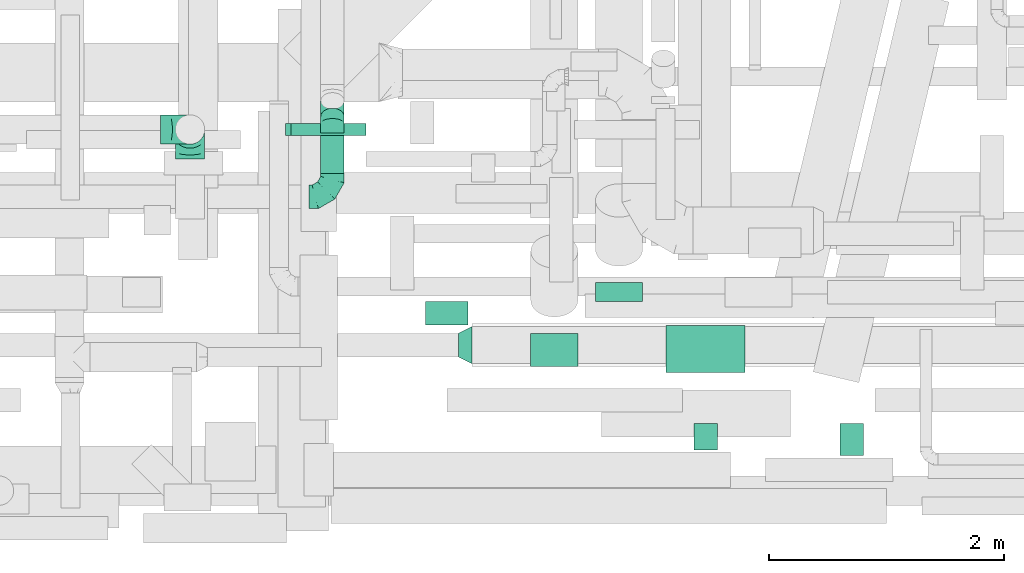
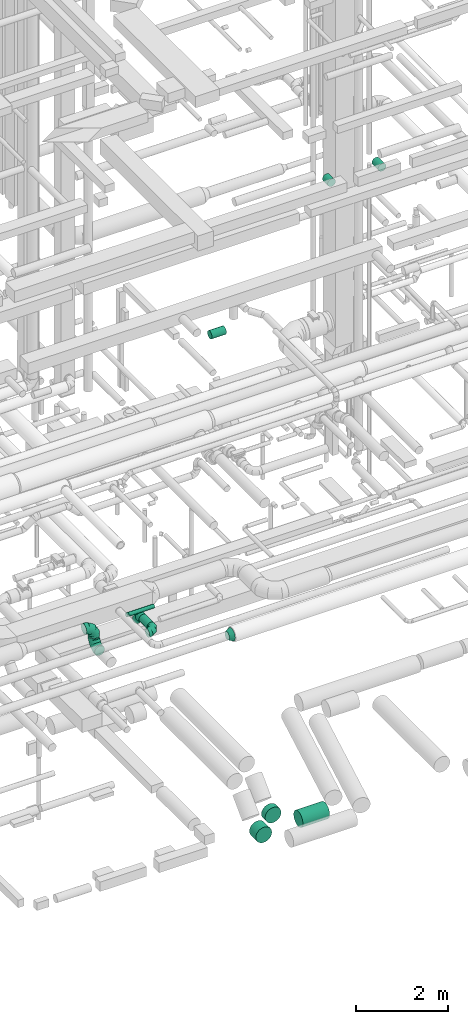
# One storey, part 163 of 337: 9 flow segments, 6 flow fittings.
"""IFC2X3 building model written with IfcOpenShell, lengths in millimetres."""

from ifc_helpers import new_model, entity, si_unit, converted_unit, derived_unit, direction, frame, origin, origin_2d_with_axis, place, context, subcontext, project, spatial, circle, extrude, faceted_brep, source, transform, mapped, material, type_object, type_shapes, element, save


model = new_model("IFC2X3")

# Units and contexts
model_context = context("Model", 3, precision=0.01, world=origin(), true_north=direction((6.12303176911189e-17, 1.0)))
body_context = subcontext(model_context, "Body", "Model", "MODEL_VIEW")
ifc_project = project(units=[si_unit("LENGTHUNIT", "METRE", prefix="MILLI"), si_unit("AREAUNIT", "SQUARE_METRE"), si_unit("VOLUMEUNIT", "CUBIC_METRE"), converted_unit("PLANEANGLEUNIT", "DEGREE", entity("IfcRatioMeasure", 0.0174532925199433), si_unit("PLANEANGLEUNIT", "RADIAN"), dimensions=[0, 0, 0, 0, 0, 0, 0]), si_unit("MASSUNIT", "GRAM", prefix="KILO"), derived_unit("MASSDENSITYUNIT", [(si_unit("MASSUNIT", "GRAM", prefix="KILO"), 1), (si_unit("LENGTHUNIT", "METRE"), -3)]), derived_unit("MOMENTOFINERTIAUNIT", [(si_unit("LENGTHUNIT", "METRE"), 4)]), si_unit("TIMEUNIT", "SECOND"), si_unit("FREQUENCYUNIT", "HERTZ"), si_unit("THERMODYNAMICTEMPERATUREUNIT", "DEGREE_CELSIUS"), derived_unit("THERMALTRANSMITTANCEUNIT", [(si_unit("MASSUNIT", "GRAM", prefix="KILO"), 1), (si_unit("THERMODYNAMICTEMPERATUREUNIT", "KELVIN"), -1), (si_unit("TIMEUNIT", "SECOND"), -3)]), derived_unit("VOLUMETRICFLOWRATEUNIT", [(si_unit("LENGTHUNIT", "METRE"), 3), (si_unit("TIMEUNIT", "SECOND"), -1)]), derived_unit("MASSFLOWRATEUNIT", [(si_unit("MASSUNIT", "GRAM", prefix="KILO"), 1), (si_unit("TIMEUNIT", "SECOND"), -1)]), derived_unit("ROTATIONALFREQUENCYUNIT", [(si_unit("TIMEUNIT", "SECOND"), -1)]), si_unit("ELECTRICCURRENTUNIT", "AMPERE"), si_unit("ELECTRICVOLTAGEUNIT", "VOLT"), si_unit("POWERUNIT", "WATT"), si_unit("FORCEUNIT", "NEWTON", prefix="KILO"), si_unit("ILLUMINANCEUNIT", "LUX"), si_unit("LUMINOUSFLUXUNIT", "LUMEN"), si_unit("LUMINOUSINTENSITYUNIT", "CANDELA"), derived_unit("USERDEFINED", [(si_unit("MASSUNIT", "GRAM", prefix="KILO"), -1), (si_unit("LENGTHUNIT", "METRE"), -2), (si_unit("TIMEUNIT", "SECOND"), 3), (si_unit("LUMINOUSFLUXUNIT", "LUMEN"), 1)]), derived_unit("LINEARVELOCITYUNIT", [(si_unit("LENGTHUNIT", "METRE"), 1), (si_unit("TIMEUNIT", "SECOND"), -1)]), si_unit("PRESSUREUNIT", "PASCAL"), derived_unit("USERDEFINED", [(si_unit("LENGTHUNIT", "METRE"), -2), (si_unit("MASSUNIT", "GRAM", prefix="KILO"), 1), (si_unit("TIMEUNIT", "SECOND"), -2)]), derived_unit("LINEARFORCEUNIT", [(si_unit("MASSUNIT", "GRAM", prefix="KILO"), 1), (si_unit("LENGTHUNIT", "METRE"), 1), (si_unit("TIMEUNIT", "SECOND"), -2), (si_unit("LENGTHUNIT", "METRE"), -1)]), derived_unit("PLANARFORCEUNIT", [(si_unit("MASSUNIT", "GRAM", prefix="KILO"), 1), (si_unit("LENGTHUNIT", "METRE"), 1), (si_unit("TIMEUNIT", "SECOND"), -2), (si_unit("LENGTHUNIT", "METRE"), -2)])], contexts=[model_context])

# Site, building, storey
site_placement = place(None, origin())
site = spatial("IfcSite", under=ifc_project, at=site_placement, CompositionType="ELEMENT")
building_placement = place(site_placement, origin())
building = spatial("IfcBuilding", under=site, at=building_placement, CompositionType="ELEMENT")
storey_placement = place(building_placement, origin())
storey = spatial("IfcBuildingStorey", under=building, at=storey_placement, CompositionType="ELEMENT", Elevation=0.0)

# Flow segments
duct_segment_type = type_object("IfcDuctSegmentType", PredefinedType="NOTDEFINED")
flow_segment_1_placement = place(storey_placement, frame((51812.5, 2198.23, -2151.6)))
element("IfcFlowSegment", 1, at=flow_segment_1_placement, inside=storey, type_object=duct_segment_type, context=body_context, shape_type="SweptSolid", body=[
    extrude(circle(Radius=200.0, at=origin_2d_with_axis()), frame((201.6, 0.0, 201.6), z_axis=(0.0, 1.0, 0.0), x_axis=(-1.0, 0.0, 0.0)), (0.0, 0.0, 1.0), 161.222382101526),
])
flow_segment_2_placement = place(storey_placement, frame((52414.1, 1596.63, -2151.6)))
element("IfcFlowSegment", 2, at=flow_segment_2_placement, inside=storey, type_object=duct_segment_type, context=body_context, shape_type="SweptSolid", body=[
    extrude(circle(Radius=200.0, at=origin_2d_with_axis()), frame((0.0, 201.6, 201.6), z_axis=(1.0, 0.0, 0.0), x_axis=(0.0, 1.0, 0.0)), (0.0, 0.0, 1.0), 670.046048913268),
])
flow_segment_3_placement = place(storey_placement, frame((51262.56, 1648.73, -2151.6)))
element("IfcFlowSegment", 3, at=flow_segment_3_placement, inside=storey, type_object=duct_segment_type, context=body_context, shape_type="SweptSolid", body=[
    extrude(circle(Radius=200.0, at=origin_2d_with_axis()), frame((201.6, 0.0, 201.6), z_axis=(0.0, 1.0, 0.0), x_axis=(-1.0, 0.0, 0.0)), (0.0, 0.0, 1.0), 279.135993523077),
])
flow_segment_4_placement = place(storey_placement, frame((50371.04, 1997.57, 11298.4)))
element("IfcFlowSegment", 4, at=flow_segment_4_placement, inside=storey, type_object=duct_segment_type, context=body_context, shape_type="SweptSolid", body=[
    extrude(circle(Radius=100.0, at=origin_2d_with_axis()), frame((0.0, 101.6, 101.6), z_axis=(1.0, 0.0, 0.0), x_axis=(0.0, -1.0, 0.0)), (0.0, 0.0, 1.0), 359.999999999961),
])
flow_segment_5_placement = place(storey_placement, frame((49226.6, 3609.08, 3398.4)))
element("IfcFlowSegment", 5, at=flow_segment_5_placement, inside=storey, type_object=duct_segment_type, context=body_context, shape_type="SweptSolid", body=[
    extrude(circle(Radius=50.0, at=origin_2d_with_axis()), frame((0.0, 51.6, 51.6), z_axis=(1.0, 0.0, 0.0), x_axis=(0.0, -1.0, 0.0)), (0.0, 0.0, 1.0), 639.999999999984),
])
flow_segment_6_placement = place(storey_placement, frame((52650.6, 940.66, 15198.4)))
element("IfcFlowSegment", 6, at=flow_segment_6_placement, inside=storey, type_object=duct_segment_type, context=body_context, shape_type="SweptSolid", body=[
    extrude(circle(Radius=100.0, at=origin_2d_with_axis()), frame((101.6, 0.0, 101.6), z_axis=(0.0, 1.0, 0.0), x_axis=(-1.0, 0.0, 0.0)), (0.0, 0.0, 1.0), 221.742634045101),
])
flow_segment_7_placement = place(storey_placement, frame((53888.6, 890.66, 15198.4)))
element("IfcFlowSegment", 7, at=flow_segment_7_placement, inside=storey, type_object=duct_segment_type, context=body_context, shape_type="SweptSolid", body=[
    extrude(circle(Radius=100.0, at=origin_2d_with_axis()), frame((101.6, 0.0, 101.6), z_axis=(0.0, 1.0, 0.0), x_axis=(-1.0, 0.0, 0.0)), (0.0, 0.0, 1.0), 271.742634045124),
])
flow_segment_8_placement = place(storey_placement, frame((49478.4, 3289.11, 3148.4)))
element("IfcFlowSegment", 8, at=flow_segment_8_placement, inside=storey, type_object=duct_segment_type, context=body_context, shape_type="SweptSolid", body=[
    extrude(circle(Radius=100.0, at=origin_2d_with_axis()), frame((101.6, 0.0, 101.6), z_axis=(0.0, 1.0, 0.0), x_axis=(-1.0, 0.0, 0.0)), (0.0, 0.0, 1.0), 340.470637764655),
])
flow_segment_9_placement = place(storey_placement, frame((49478.4, 3698.7, 2986.27)))
element("IfcFlowSegment", 9, at=flow_segment_9_placement, inside=storey, type_object=duct_segment_type, context=body_context, shape_type="SweptSolid", body=[
    extrude(circle(Radius=100.0, at=origin_2d_with_axis()), frame((101.6, 205.15, 72.31), z_axis=(0.0, -0.707106781186548, 0.707106781186548), x_axis=(-1.0, 0.0, 0.0)), (0.0, 0.0, 1.0), 187.867965643922),
])

# Flow fittings
ifc_material = material()
duct_fitting_type_1 = type_object("IfcDuctFittingType", PredefinedType="NOTDEFINED", material=ifc_material)
shared_shape_1 = source(origin(), body_context, "Body", "Brep", [
    faceted_brep([(-250.0, 0.0, -125.0), (-250.0, -32.35, -120.74), (-250.0, -62.5, -108.25), (-250.0, -88.39, -88.39), (-250.0, -108.25, -62.5), (-250.0, -120.74, -32.35), (-250.0, -125.0, 0.0), (-250.0, -120.74, 32.35), (-250.0, -108.25, 62.5), (-250.0, -88.39, 88.39), (-250.0, -62.5, 108.25), (-250.0, -32.35, 120.74), (-250.0, 0.0, 125.0), (-250.0, 32.35, 120.74), (-250.0, 62.5, 108.25), (-250.0, 88.39, 88.39), (-250.0, 108.25, 62.5), (-250.0, 120.74, 32.35), (-250.0, 125.0, 0.0), (-250.0, 120.74, -32.35), (-250.0, 108.25, -62.5), (-250.0, 88.39, -88.39), (-250.0, 62.5, -108.25), (-250.0, 32.35, -120.74), (-191.68, 32.35, 120.74), (-199.76, 62.5, 108.25), (-183.01, 0.0, 125.0), (-206.7, 88.39, 88.39), (-215.37, 120.74, 32.35), (-216.51, 125.0, 0.0), (-212.02, 108.25, 62.5), (-212.02, 108.25, -62.5), (-206.7, 88.39, -88.39), (-215.37, 120.74, -32.35), (-191.68, 32.35, -120.74), (-183.01, 0.0, -125.0), (-199.76, 62.5, -108.25), (-174.34, -32.35, -120.74), (-166.27, -62.5, -108.25), (-159.33, -88.39, -88.39), (-154.01, -108.25, -62.5), (-150.66, -120.74, -32.35), (-149.52, -125.0, 0.0), (-150.66, -120.74, 32.35), (-154.01, -108.25, 62.5), (-159.33, -88.39, 88.39), (-166.27, -62.5, 108.25), (-174.34, -32.35, 120.74), (-90.67, 90.67, 120.74), (-112.74, 112.74, 108.25), (-66.99, 66.99, 125.0), (-131.69, 131.69, 88.39), (-146.23, 146.23, 62.5), (-155.38, 155.38, 32.35), (-158.49, 158.49, 0.0), (-155.38, 155.38, -32.35), (-146.23, 146.23, -62.5), (-131.69, 131.69, -88.39), (-90.67, 90.67, -120.74), (-66.99, 66.99, -125.0), (-112.74, 112.74, -108.25), (-43.3, 43.3, -120.74), (-21.23, 21.23, -108.25), (-2.28, 2.28, -88.39), (12.26, -12.26, -62.5), (21.4, -21.4, -32.35), (24.52, -24.52, 0.0), (21.4, -21.4, 32.35), (12.26, -12.26, 62.5), (-2.28, 2.28, 88.39), (-21.23, 21.23, 108.25), (-43.3, 43.3, 120.74), (-32.35, 191.68, 120.74), (-62.5, 199.76, 108.25), (0.0, 183.01, 125.0), (-88.39, 206.7, 88.39), (-108.25, 212.02, 62.5), (-120.74, 215.37, 32.35), (-125.0, 216.51, 0.0), (-120.74, 215.37, -32.35), (-108.25, 212.02, -62.5), (-88.39, 206.7, -88.39), (-32.35, 191.68, -120.74), (0.0, 183.01, -125.0), (-62.5, 199.76, -108.25), (32.35, 174.34, -120.74), (62.5, 166.27, -108.25), (88.39, 159.33, -88.39), (108.25, 154.01, -62.5), (120.74, 150.66, -32.35), (125.0, 149.52, 0.0), (120.74, 150.66, 32.35), (108.25, 154.01, 62.5), (88.39, 159.33, 88.39), (62.5, 166.27, 108.25), (32.35, 174.34, 120.74), (-32.35, 250.0, -120.74), (-62.5, 250.0, -108.25), (-88.39, 250.0, -88.39), (-108.25, 250.0, -62.5), (-120.74, 250.0, -32.35), (-125.0, 250.0, 0.0), (-120.74, 250.0, 32.35), (-108.25, 250.0, 62.5), (-88.39, 250.0, 88.39), (-62.5, 250.0, 108.25), (-32.35, 250.0, 120.74), (0.0, 250.0, 125.0), (32.35, 250.0, 120.74), (62.5, 250.0, 108.25), (88.39, 250.0, 88.39), (108.25, 250.0, 62.5), (120.74, 250.0, 32.35), (125.0, 250.0, 0.0), (120.74, 250.0, -32.35), (108.25, 250.0, -62.5), (88.39, 250.0, -88.39), (62.5, 250.0, -108.25), (32.35, 250.0, -120.74), (0.0, 250.0, -125.0)], [[[0, 1, 2, 3, 4, 5, 6, 7, 8, 9, 10, 11, 12, 13, 14, 15, 16, 17, 18, 19, 20, 21, 22, 23]], [[24, 25, 14, 13]], [[26, 24, 13, 12]], [[14, 25, 27, 15]], [[28, 29, 18, 17]], [[30, 28, 17, 16]], [[15, 27, 30, 16]], [[20, 31, 32, 21]], [[33, 31, 20, 19]], [[18, 29, 33, 19]], [[34, 35, 0, 23]], [[36, 34, 23, 22]], [[21, 32, 36, 22]], [[1, 0, 35, 37]], [[2, 1, 37, 38]], [[38, 39, 3, 2]], [[5, 4, 40, 41]], [[6, 5, 41, 42]], [[39, 40, 4, 3]], [[6, 42, 43, 7]], [[7, 43, 44, 8]], [[8, 44, 45, 9]], [[9, 45, 46, 10]], [[10, 46, 47, 11]], [[26, 12, 11, 47]], [[48, 49, 25, 24]], [[50, 48, 24, 26]], [[27, 25, 49, 51]], [[52, 53, 28, 30]], [[51, 52, 30, 27]], [[29, 28, 53, 54]], [[55, 56, 31, 33]], [[54, 55, 33, 29]], [[32, 31, 56, 57]], [[58, 59, 35, 34]], [[60, 58, 34, 36]], [[57, 60, 36, 32]], [[37, 35, 59, 61]], [[38, 37, 61, 62]], [[39, 38, 62, 63]], [[41, 40, 64, 65]], [[42, 41, 65, 66]], [[63, 64, 40, 39]], [[43, 42, 66, 67]], [[44, 43, 67, 68]], [[68, 69, 45, 44]], [[46, 45, 69, 70]], [[47, 46, 70, 71]], [[26, 47, 71, 50]], [[72, 73, 49, 48]], [[74, 72, 48, 50]], [[51, 49, 73, 75]], [[76, 77, 53, 52]], [[75, 76, 52, 51]], [[54, 53, 77, 78]], [[79, 80, 56, 55]], [[78, 79, 55, 54]], [[57, 56, 80, 81]], [[82, 83, 59, 58]], [[84, 82, 58, 60]], [[81, 84, 60, 57]], [[61, 59, 83, 85]], [[62, 61, 85, 86]], [[63, 62, 86, 87]], [[65, 64, 88, 89]], [[66, 65, 89, 90]], [[87, 88, 64, 63]], [[67, 66, 90, 91]], [[68, 67, 91, 92]], [[92, 93, 69, 68]], [[70, 69, 93, 94]], [[71, 70, 94, 95]], [[50, 71, 95, 74]], [[96, 97, 98, 99, 100, 101, 102, 103, 104, 105, 106, 107, 108, 109, 110, 111, 112, 113, 114, 115, 116, 117, 118, 119]], [[72, 74, 107, 106]], [[73, 72, 106, 105]], [[75, 73, 105, 104]], [[77, 76, 103, 102]], [[78, 77, 102, 101]], [[75, 104, 103, 76]], [[78, 101, 100, 79]], [[79, 100, 99, 80]], [[80, 99, 98, 81]], [[84, 97, 96, 82]], [[82, 96, 119, 83]], [[84, 81, 98, 97]], [[83, 119, 118, 85]], [[85, 118, 117, 86]], [[116, 87, 86, 117]], [[88, 115, 114, 89]], [[89, 114, 113, 90]], [[115, 88, 87, 116]], [[91, 90, 113, 112]], [[92, 91, 112, 111]], [[111, 110, 93, 92]], [[95, 94, 109, 108]], [[74, 95, 108, 107]], [[110, 109, 94, 93]]]),
])
type_shapes(duct_fitting_type_1, [shared_shape_1])
for number, where, z_axis, x_axis in (
    (10, (48369.84, 3661.24, 3450.0), (0.0, 1.0, 0.0), (1.0, 0.0, 0.0)),
    (11, (48369.84, 3661.24, 2940.0), (-1.0, 0.0, 0.0), (0.0, 0.0, -1.0)),
):
    element("IfcFlowFitting", number, at=place(storey_placement, frame(where, z_axis=z_axis, x_axis=x_axis)), inside=storey, type_object=duct_fitting_type_1, material=ifc_material, context=body_context, shape_type="MappedRepresentation", body=[
        mapped(shared_shape_1, transform((0.0, 0.0, 0.0), scale=1.0)),
    ])
duct_fitting_type_2 = type_object("IfcDuctFittingType", PredefinedType="NOTDEFINED", material=ifc_material)
shared_shape_2 = source(origin(), body_context, "Body", "Brep", [
    faceted_brep([(-200.0, 0.0, -100.0), (-200.0, -25.88, -96.59), (-200.0, -50.0, -86.6), (-200.0, -70.71, -70.71), (-200.0, -86.6, -50.0), (-200.0, -96.59, -25.88), (-200.0, -100.0, 0.0), (-200.0, -96.59, 25.88), (-200.0, -86.6, 50.0), (-200.0, -70.71, 70.71), (-200.0, -50.0, 86.6), (-200.0, -25.88, 96.59), (-200.0, 0.0, 100.0), (-200.0, 25.88, 96.59), (-200.0, 50.0, 86.6), (-200.0, 70.71, 70.71), (-200.0, 86.6, 50.0), (-200.0, 96.59, 25.88), (-200.0, 100.0, 0.0), (-200.0, 96.59, -25.88), (-200.0, 86.6, -50.0), (-200.0, 70.71, -70.71), (-200.0, 50.0, -86.6), (-200.0, 25.88, -96.59), (-153.35, 25.88, 96.59), (-159.81, 50.0, 86.6), (-146.41, 0.0, 100.0), (-165.36, 70.71, 70.71), (-172.29, 96.59, 25.88), (-173.21, 100.0, 0.0), (-169.62, 86.6, 50.0), (-169.62, 86.6, -50.0), (-165.36, 70.71, -70.71), (-172.29, 96.59, -25.88), (-153.35, 25.88, -96.59), (-146.41, 0.0, -100.0), (-159.81, 50.0, -86.6), (-139.48, -25.88, -96.59), (-133.01, -50.0, -86.6), (-127.46, -70.71, -70.71), (-123.21, -86.6, -50.0), (-120.53, -96.59, -25.88), (-119.62, -100.0, 0.0), (-120.53, -96.59, 25.88), (-123.21, -86.6, 50.0), (-127.46, -70.71, 70.71), (-133.01, -50.0, 86.6), (-139.48, -25.88, 96.59), (-72.54, 72.54, 96.59), (-90.19, 90.19, 86.6), (-53.59, 53.59, 100.0), (-105.35, 105.35, 70.71), (-116.99, 116.99, 50.0), (-124.3, 124.3, 25.88), (-126.79, 126.79, 0.0), (-124.3, 124.3, -25.88), (-116.99, 116.99, -50.0), (-105.35, 105.35, -70.71), (-72.54, 72.54, -96.59), (-53.59, 53.59, -100.0), (-90.19, 90.19, -86.6), (-34.64, 34.64, -96.59), (-16.99, 16.99, -86.6), (-1.83, 1.83, -70.71), (9.81, -9.81, -50.0), (17.12, -17.12, -25.88), (19.62, -19.62, 0.0), (17.12, -17.12, 25.88), (9.81, -9.81, 50.0), (-1.83, 1.83, 70.71), (-16.99, 16.99, 86.6), (-34.64, 34.64, 96.59), (-25.88, 153.35, 96.59), (-50.0, 159.81, 86.6), (0.0, 146.41, 100.0), (-70.71, 165.36, 70.71), (-86.6, 169.62, 50.0), (-96.59, 172.29, 25.88), (-100.0, 173.21, 0.0), (-96.59, 172.29, -25.88), (-86.6, 169.62, -50.0), (-70.71, 165.36, -70.71), (-25.88, 153.35, -96.59), (0.0, 146.41, -100.0), (-50.0, 159.81, -86.6), (25.88, 139.48, -96.59), (50.0, 133.01, -86.6), (70.71, 127.46, -70.71), (86.6, 123.21, -50.0), (96.59, 120.53, -25.88), (100.0, 119.62, 0.0), (96.59, 120.53, 25.88), (86.6, 123.21, 50.0), (70.71, 127.46, 70.71), (50.0, 133.01, 86.6), (25.88, 139.48, 96.59), (-25.88, 200.0, -96.59), (-50.0, 200.0, -86.6), (-70.71, 200.0, -70.71), (-86.6, 200.0, -50.0), (-96.59, 200.0, -25.88), (-100.0, 200.0, 0.0), (-96.59, 200.0, 25.88), (-86.6, 200.0, 50.0), (-70.71, 200.0, 70.71), (-50.0, 200.0, 86.6), (-25.88, 200.0, 96.59), (0.0, 200.0, 100.0), (25.88, 200.0, 96.59), (50.0, 200.0, 86.6), (70.71, 200.0, 70.71), (86.6, 200.0, 50.0), (96.59, 200.0, 25.88), (100.0, 200.0, 0.0), (96.59, 200.0, -25.88), (86.6, 200.0, -50.0), (70.71, 200.0, -70.71), (50.0, 200.0, -86.6), (25.88, 200.0, -96.59), (0.0, 200.0, -100.0)], [[[0, 1, 2, 3, 4, 5, 6, 7, 8, 9, 10, 11, 12, 13, 14, 15, 16, 17, 18, 19, 20, 21, 22, 23]], [[24, 25, 14, 13]], [[26, 24, 13, 12]], [[14, 25, 27, 15]], [[28, 29, 18, 17]], [[30, 28, 17, 16]], [[15, 27, 30, 16]], [[20, 31, 32, 21]], [[33, 31, 20, 19]], [[18, 29, 33, 19]], [[34, 35, 0, 23]], [[36, 34, 23, 22]], [[32, 36, 22, 21]], [[1, 0, 35, 37]], [[2, 1, 37, 38]], [[38, 39, 3, 2]], [[5, 4, 40, 41]], [[6, 5, 41, 42]], [[39, 40, 4, 3]], [[6, 42, 43, 7]], [[7, 43, 44, 8]], [[8, 44, 45, 9]], [[9, 45, 46, 10]], [[10, 46, 47, 11]], [[26, 12, 11, 47]], [[48, 49, 25, 24]], [[50, 48, 24, 26]], [[27, 25, 49, 51]], [[52, 53, 28, 30]], [[51, 52, 30, 27]], [[29, 28, 53, 54]], [[55, 56, 31, 33]], [[54, 55, 33, 29]], [[32, 31, 56, 57]], [[58, 59, 35, 34]], [[60, 58, 34, 36]], [[57, 60, 36, 32]], [[37, 35, 59, 61]], [[38, 37, 61, 62]], [[39, 38, 62, 63]], [[41, 40, 64, 65]], [[42, 41, 65, 66]], [[63, 64, 40, 39]], [[43, 42, 66, 67]], [[44, 43, 67, 68]], [[68, 69, 45, 44]], [[46, 45, 69, 70]], [[47, 46, 70, 71]], [[26, 47, 71, 50]], [[72, 73, 49, 48]], [[74, 72, 48, 50]], [[51, 49, 73, 75]], [[76, 77, 53, 52]], [[75, 76, 52, 51]], [[54, 53, 77, 78]], [[79, 80, 56, 55]], [[78, 79, 55, 54]], [[57, 56, 80, 81]], [[82, 83, 59, 58]], [[84, 82, 58, 60]], [[81, 84, 60, 57]], [[61, 59, 83, 85]], [[62, 61, 85, 86]], [[63, 62, 86, 87]], [[65, 64, 88, 89]], [[66, 65, 89, 90]], [[87, 88, 64, 63]], [[67, 66, 90, 91]], [[68, 67, 91, 92]], [[92, 93, 69, 68]], [[70, 69, 93, 94]], [[71, 70, 94, 95]], [[50, 71, 95, 74]], [[96, 97, 98, 99, 100, 101, 102, 103, 104, 105, 106, 107, 108, 109, 110, 111, 112, 113, 114, 115, 116, 117, 118, 119]], [[72, 74, 107, 106]], [[73, 72, 106, 105]], [[75, 73, 105, 104]], [[102, 101, 78, 77]], [[103, 102, 77, 76]], [[75, 104, 103, 76]], [[78, 101, 100, 79]], [[79, 100, 99, 80]], [[80, 99, 98, 81]], [[84, 97, 96, 82]], [[82, 96, 119, 83]], [[84, 81, 98, 97]], [[118, 117, 86, 85]], [[119, 118, 85, 83]], [[116, 87, 86, 117]], [[88, 115, 114, 89]], [[89, 114, 113, 90]], [[115, 88, 87, 116]], [[91, 90, 113, 112]], [[92, 91, 112, 111]], [[111, 110, 93, 92]], [[95, 94, 109, 108]], [[74, 95, 108, 107]], [[110, 109, 94, 93]]]),
])
type_shapes(duct_fitting_type_2, [shared_shape_2])
flow_fitting_1_placement = place(storey_placement, frame((49580.0, 3089.11, 3250.0)))
element("IfcFlowFitting", 12, at=flow_fitting_1_placement, inside=storey, type_object=duct_fitting_type_2, material=ifc_material, context=body_context, shape_type="MappedRepresentation", body=[
    mapped(shared_shape_2, transform((0.0, 0.0, 0.0), scale=1.0)),
])
duct_fitting_type_3 = type_object("IfcDuctFittingType", PredefinedType="NOTDEFINED", material=ifc_material)
shared_shape_3 = source(origin(), body_context, "Body", "Brep", [
    faceted_brep([(20.0, 12.94, -48.3), (20.0, 25.0, -43.3), (20.0, 35.36, -35.36), (20.0, 43.3, -25.0), (20.0, 48.3, -12.94), (20.0, 50.0, 0.0), (20.0, 48.3, 12.94), (20.0, 43.3, 25.0), (20.0, 35.36, 35.36), (20.0, 25.0, 43.3), (20.0, 12.94, 48.3), (20.0, 0.0, 50.0), (20.0, -12.94, 48.3), (20.0, -25.0, 43.3), (20.0, -35.36, 35.36), (20.0, -43.3, 25.0), (20.0, -48.3, 12.94), (20.0, -50.0, 0.0), (20.0, -48.3, -12.94), (20.0, -43.3, -25.0), (20.0, -35.36, -35.36), (20.0, -25.0, -43.3), (20.0, -12.94, -48.3), (20.0, 0.0, -50.0), (0.0, 0.0, 50.0), (0.0, 12.94, 48.3), (-23.65, 12.94, 48.3), (-23.65, 0.0, 50.0), (0.0, 25.0, 43.3), (-23.65, 25.0, 43.3), (0.0, 35.36, 35.36), (-23.65, 35.36, 35.36), (0.0, 43.3, 25.0), (0.0, 48.3, 12.94), (-23.65, 48.3, 12.94), (-23.65, 43.3, 25.0), (0.0, 50.0, 0.0), (-23.65, 50.0, 0.0), (0.0, 48.3, -12.94), (-23.65, 48.3, -12.94), (0.0, 43.3, -25.0), (-23.65, 43.3, -25.0), (0.0, 35.36, -35.36), (-23.65, 35.36, -35.36), (0.0, 25.0, -43.3), (0.0, 12.94, -48.3), (-23.65, 12.94, -48.3), (-23.65, 25.0, -43.3), (0.0, 0.0, -50.0), (-23.65, 0.0, -50.0), (0.0, -12.94, -48.3), (-23.65, -12.94, -48.3), (0.0, -25.0, -43.3), (-23.65, -25.0, -43.3), (0.0, -35.36, -35.36), (-23.65, -35.36, -35.36), (0.0, -43.3, -25.0), (0.0, -48.3, -12.94), (-23.65, -48.3, -12.94), (-23.65, -43.3, -25.0), (0.0, -50.0, 0.0), (-23.65, -50.0, 0.0), (0.0, -48.3, 12.94), (-23.65, -48.3, 12.94), (0.0, -43.3, 25.0), (-23.65, -43.3, 25.0), (0.0, -35.36, 35.36), (-23.65, -35.36, 35.36), (0.0, -25.0, 43.3), (0.0, -12.94, 48.3), (-23.65, -12.94, 48.3), (-23.65, -25.0, 43.3)], [[[0, 1, 2, 3, 4, 5, 6, 7, 8, 9, 10, 11, 12, 13, 14, 15, 16, 17, 18, 19, 20, 21, 22, 23]], [[24, 11, 10, 25, 26, 27]], [[25, 10, 9, 28, 29, 26]], [[28, 9, 8, 30, 31, 29]], [[32, 7, 6, 33, 34, 35]], [[33, 6, 5, 36, 37, 34]], [[30, 8, 7, 32, 35, 31]], [[36, 5, 4, 38, 39, 37]], [[38, 4, 3, 40, 41, 39]], [[40, 3, 2, 42, 43, 41]], [[44, 1, 0, 45, 46, 47]], [[45, 0, 23, 48, 49, 46]], [[42, 2, 1, 44, 47, 43]], [[48, 23, 22, 50, 51, 49]], [[50, 22, 21, 52, 53, 51]], [[52, 21, 20, 54, 55, 53]], [[56, 19, 18, 57, 58, 59]], [[57, 18, 17, 60, 61, 58]], [[54, 20, 19, 56, 59, 55]], [[60, 17, 16, 62, 63, 61]], [[62, 16, 15, 64, 65, 63]], [[64, 15, 14, 66, 67, 65]], [[68, 13, 12, 69, 70, 71]], [[69, 12, 11, 24, 27, 70]], [[66, 14, 13, 68, 71, 67]], [[49, 51, 53, 55, 59, 58, 61, 63, 65, 67, 71, 70, 27, 26, 29, 31, 35, 34, 37, 39, 41, 43, 47, 46]]]),
])
type_shapes(duct_fitting_type_3, [shared_shape_3])
flow_fitting_2_placement = place(storey_placement, frame((49206.6, 3660.67, 3450.0), z_axis=(0.0, 0.0, -1.0), x_axis=(1.0, 0.0, 0.0)))
element("IfcFlowFitting", 13, at=flow_fitting_2_placement, inside=storey, type_object=duct_fitting_type_3, material=ifc_material, context=body_context, shape_type="MappedRepresentation", body=[
    mapped(shared_shape_3, transform((0.0, 0.0, 0.0), scale=1.0)),
])
duct_fitting_type_4 = type_object("IfcDuctFittingType", PredefinedType="NOTDEFINED", material=ifc_material)
shared_shape_4 = source(origin(), body_context, "Body", "Brep", [
    faceted_brep([(-82.84, 0.0, -100.0), (-82.84, -25.88, -96.59), (-82.84, -50.0, -86.6), (-82.84, -70.71, -70.71), (-82.84, -86.6, -50.0), (-82.84, -96.59, -25.88), (-82.84, -100.0, 0.0), (-82.84, -96.59, 25.88), (-82.84, -86.6, 50.0), (-82.84, -70.71, 70.71), (-82.84, -50.0, 86.6), (-82.84, -25.88, 96.59), (-82.84, 0.0, 100.0), (-82.84, 25.88, 96.59), (-82.84, 50.0, 86.6), (-82.84, 70.71, 70.71), (-82.84, 86.6, 50.0), (-82.84, 96.59, 25.88), (-82.84, 100.0, 0.0), (-82.84, 96.59, -25.88), (-82.84, 86.6, -50.0), (-82.84, 70.71, -70.71), (-82.84, 50.0, -86.6), (-82.84, 25.88, -96.59), (-10.72, 25.88, 96.59), (-20.71, 50.0, 86.6), (0.0, 0.0, 100.0), (-29.29, 70.71, 70.71), (-35.87, 86.6, 50.0), (-40.01, 96.59, 25.88), (-41.42, 100.0, 0.0), (-40.01, 96.59, -25.88), (-35.87, 86.6, -50.0), (-29.29, 70.71, -70.71), (-10.72, 25.88, -96.59), (0.0, 0.0, -100.0), (-20.71, 50.0, -86.6), (10.72, -25.88, -96.59), (20.71, -50.0, -86.6), (29.29, -70.71, -70.71), (35.87, -86.6, -50.0), (40.01, -96.59, -25.88), (41.42, -100.0, 0.0), (40.01, -96.59, 25.88), (35.87, -86.6, 50.0), (29.29, -70.71, 70.71), (20.71, -50.0, 86.6), (10.72, -25.88, 96.59), (58.58, 58.58, 100.0), (40.28, 76.88, 96.59), (23.22, 93.93, 86.6), (8.58, 108.58, 70.71), (-2.66, 119.82, 50.0), (-9.72, 126.88, 25.88), (-12.13, 129.29, 0.0), (-9.72, 126.88, -25.88), (-2.66, 119.82, -50.0), (8.58, 108.58, -70.71), (23.22, 93.93, -86.6), (40.28, 76.88, -96.59), (58.58, 58.58, -100.0), (76.88, 40.28, -96.59), (93.93, 23.22, -86.6), (108.58, 8.58, -70.71), (119.82, -2.66, -50.0), (126.88, -9.72, -25.88), (129.29, -12.13, 0.0), (126.88, -9.72, 25.88), (119.82, -2.66, 50.0), (108.58, 8.58, 70.71), (93.93, 23.22, 86.6), (76.88, 40.28, 96.59)], [[[0, 1, 2, 3, 4, 5, 6, 7, 8, 9, 10, 11, 12, 13, 14, 15, 16, 17, 18, 19, 20, 21, 22, 23]], [[24, 25, 14, 13]], [[26, 24, 13, 12]], [[14, 25, 27, 15]], [[28, 29, 17, 16]], [[28, 16, 15, 27]], [[30, 18, 17, 29]], [[31, 32, 20, 19]], [[30, 31, 19, 18]], [[32, 33, 21, 20]], [[34, 35, 0, 23]], [[36, 34, 23, 22]], [[33, 36, 22, 21]], [[1, 0, 35, 37]], [[2, 1, 37, 38]], [[38, 39, 3, 2]], [[5, 4, 40, 41]], [[6, 5, 41, 42]], [[39, 40, 4, 3]], [[6, 42, 43, 7]], [[7, 43, 44, 8]], [[8, 44, 45, 9]], [[9, 45, 46, 10]], [[10, 46, 47, 11]], [[26, 12, 11, 47]], [[24, 26, 48, 49]], [[25, 24, 49, 50]], [[27, 25, 50, 51]], [[29, 28, 52, 53]], [[30, 29, 53, 54]], [[51, 52, 28, 27]], [[30, 54, 55, 31]], [[31, 55, 56, 32]], [[57, 33, 32, 56]], [[36, 58, 59, 34]], [[34, 59, 60, 35]], [[58, 36, 33, 57]], [[35, 60, 61, 37]], [[37, 61, 62, 38]], [[63, 39, 38, 62]], [[40, 64, 65, 41]], [[41, 65, 66, 42]], [[64, 40, 39, 63]], [[43, 42, 66, 67]], [[44, 43, 67, 68]], [[68, 69, 45, 44]], [[47, 46, 70, 71]], [[26, 47, 71, 48]], [[69, 70, 46, 45]], [[59, 58, 57, 56, 55, 54, 53, 52, 51, 50, 49, 48, 71, 70, 69, 68, 67, 66, 65, 64, 63, 62, 61, 60]]]),
])
type_shapes(duct_fitting_type_4, [shared_shape_4])
flow_fitting_3_placement = place(storey_placement, frame((49580.0, 3712.42, 3250.0), z_axis=(1.0, 0.0, 0.0), x_axis=(0.0, -0.707106781186527, 0.707106781186568)))
element("IfcFlowFitting", 14, at=flow_fitting_3_placement, inside=storey, type_object=duct_fitting_type_4, material=ifc_material, context=body_context, shape_type="MappedRepresentation", body=[
    mapped(shared_shape_4, transform((0.0, 0.0, 0.0), scale=1.0)),
])
duct_fitting_type_5 = type_object("IfcDuctFittingType", PredefinedType="NOTDEFINED", material=ifc_material)
shared_shape_5 = source(origin(), body_context, "Body", "Brep", [
    faceted_brep([(115.0, 80.9, -58.78), (115.0, 95.11, -30.9), (115.0, 100.0, 0.0), (115.0, 95.11, 30.9), (115.0, 80.9, 58.78), (115.0, 58.78, 80.9), (115.0, 30.9, 95.11), (115.0, 0.0, 100.0), (115.0, -30.9, 95.11), (115.0, -58.78, 80.9), (115.0, -80.9, 58.78), (115.0, -95.11, 30.9), (115.0, -100.0, 0.0), (115.0, -95.11, -30.9), (115.0, -80.9, -58.78), (115.0, -58.78, -80.9), (115.0, -30.9, -95.11), (115.0, 0.0, -100.0), (115.0, 30.9, -95.11), (115.0, 58.78, -80.9), (0.0, -40.76, -152.13), (0.0, -78.75, -136.4), (0.0, -111.37, -111.37), (0.0, -136.4, -78.75), (0.0, -152.13, -40.76), (0.0, -157.5, 0.0), (0.0, -152.13, 40.76), (0.0, -136.4, 78.75), (0.0, -111.37, 111.37), (0.0, -78.75, 136.4), (0.0, -40.76, 152.13), (0.0, 0.0, 157.5), (0.0, 40.76, 152.13), (0.0, 78.75, 136.4), (0.0, 111.37, 111.37), (0.0, 136.4, 78.75), (0.0, 152.13, 40.76), (0.0, 157.5, 0.0), (0.0, 152.13, -40.76), (0.0, 136.4, -78.75), (0.0, 111.37, -111.37), (0.0, 78.75, -136.4), (0.0, 40.76, -152.13), (0.0, 0.0, -157.5)], [[[0, 1, 2, 3, 4, 5, 6, 7, 8, 9, 10, 11, 12, 13, 14, 15, 16, 17, 18, 19]], [[20, 21, 22, 23, 24, 25, 26, 27, 28, 29, 30, 31, 32, 33, 34, 35, 36, 37, 38, 39, 40, 41, 42, 43]], [[6, 5, 33]], [[7, 6, 32]], [[7, 32, 31]], [[32, 6, 33]], [[5, 34, 33]], [[35, 4, 3]], [[36, 3, 2]], [[35, 34, 4]], [[37, 36, 2]], [[35, 3, 36]], [[4, 34, 5]], [[11, 10, 27]], [[12, 11, 26]], [[12, 26, 25]], [[26, 11, 27]], [[10, 28, 27]], [[29, 9, 8]], [[30, 8, 7]], [[29, 28, 9]], [[31, 30, 7]], [[29, 8, 30]], [[9, 28, 10]], [[16, 15, 21]], [[17, 16, 20]], [[17, 20, 43]], [[20, 16, 21]], [[15, 22, 21]], [[23, 14, 13]], [[24, 13, 12]], [[23, 22, 14]], [[25, 24, 12]], [[23, 13, 24]], [[14, 22, 15]], [[1, 0, 39]], [[2, 1, 38]], [[2, 38, 37]], [[38, 1, 39]], [[0, 40, 39]], [[41, 19, 18]], [[42, 18, 17]], [[41, 40, 19]], [[43, 42, 17]], [[41, 18, 42]], [[19, 40, 0]]]),
])
type_shapes(duct_fitting_type_5, [shared_shape_5])
flow_fitting_4_placement = place(storey_placement, frame((50763.55, 1829.37, 3500.0), z_axis=(0.0, 0.0, 1.0), x_axis=(-1.0, 0.0, 0.0)))
element("IfcFlowFitting", 15, at=flow_fitting_4_placement, inside=storey, type_object=duct_fitting_type_5, material=ifc_material, context=body_context, shape_type="MappedRepresentation", body=[
    mapped(shared_shape_5, transform((0.0, 0.0, 0.0), scale=1.0)),
])

save(model, "model.ifc")
